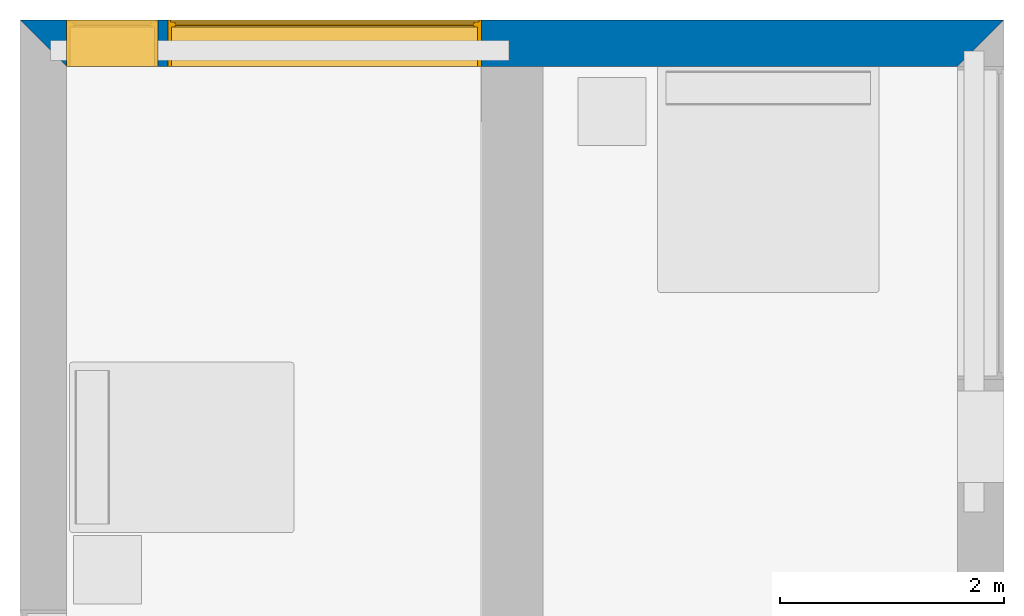
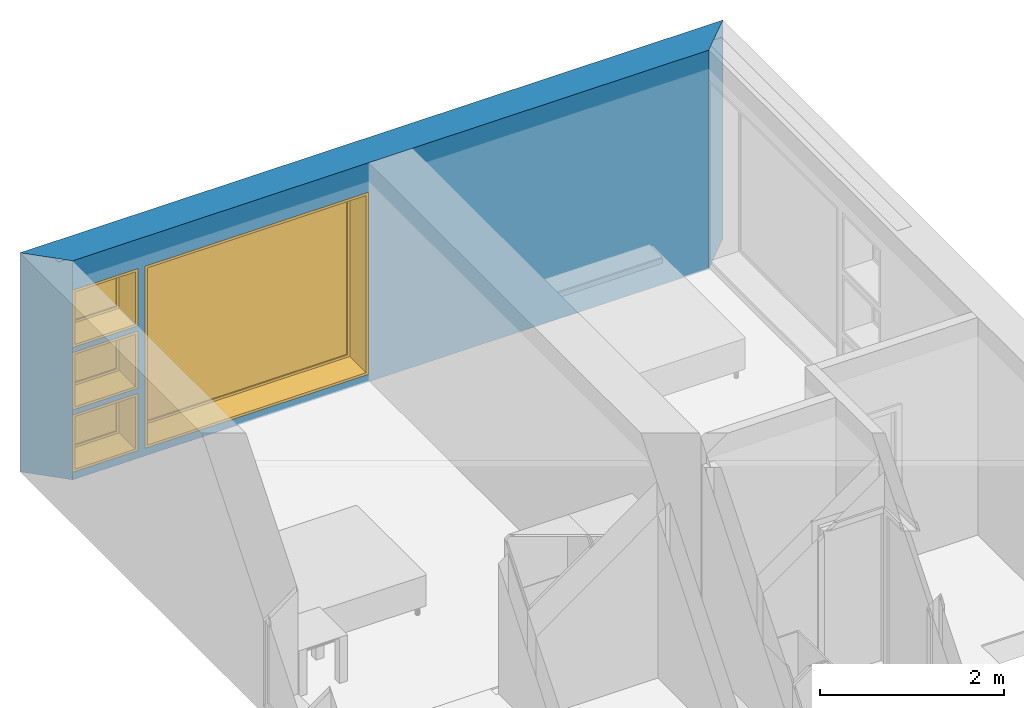
# One storey, part 4 of 16: 4 windows, 1 wall, 4 openings.
"""IFC2X3 building model written with IfcOpenShell, lengths in metres."""

from ifc_helpers import new_model, entity, si_unit, converted_unit, frame, frame_2d, origin, origin_2d_with_axis, place, context, project, spatial, polyline, rectangle, outline, extrude, source, transform, mapped, material, layer, layer_set, layer_usage, type_object, type_shapes, element, fill, save


model = new_model("IFC2X3")

# Units and contexts
model_context = context("Model", 3, precision=1e-09, world=origin())
plan_context = context("Plan", 3, precision=1e-09, world=origin())
ifc_project = project(units=[si_unit("LENGTHUNIT", "METRE"), si_unit("AREAUNIT", "SQUARE_METRE"), si_unit("VOLUMEUNIT", "CUBIC_METRE"), converted_unit("PLANEANGLEUNIT", "DEGREE", entity("IfcRatioMeasure", 0.01745329251994328), si_unit("PLANEANGLEUNIT", "RADIAN"), dimensions=[0, 0, 0, 0, 0, 0, 0]), si_unit("TIMEUNIT", "SECOND")], contexts=[model_context, plan_context])

# Site, building, storey
site_placement = place(None, origin())
site = spatial("IfcSite", under=ifc_project, at=site_placement, CompositionType="ELEMENT")
building_placement = place(site_placement, origin())
building = spatial("IfcBuilding", under=site, at=building_placement, CompositionType="ELEMENT")
storey_placement = place(building_placement, frame((0.0, 0.0, 3.100000000000196)))
storey = spatial("IfcBuildingStorey", under=building, at=storey_placement, Name="Level 2", CompositionType="ELEMENT", Elevation=3.100000000000196)

# Wall, openings, windows
ifc_material_1 = material(Name="Masonry - Brick")
ifc_layer_1 = layer(ifc_material_1, 0.092)
ifc_material_2 = material(Name="Misc. Air Layers - Air Space")
ifc_layer_2 = layer(ifc_material_2, 0.025)
ifc_material_3 = material(Name="Insulation / Thermal Barriers - Rigid insulation")
ifc_layer_3 = layer(ifc_material_3, 0.05)
ifc_material_4 = material(Name="Masonry - Concrete Block")
ifc_layer_4 = layer(ifc_material_4, 0.193)
ifc_material_5 = material(Name="Metal - Stud Layer")
ifc_layer_5 = layer(ifc_material_5, 0.041)
ifc_material_6 = material(Name="Plasterboard")
ifc_layer_6 = layer(ifc_material_6, 0.016)
ifc_layer_set = layer_set([ifc_layer_1, ifc_layer_2, ifc_layer_3, ifc_layer_4, ifc_layer_5, ifc_layer_6], Name="Basic Wall:Exterior - Brick on Block")
ifc_layer_usage = layer_usage(ifc_layer_set, "AXIS2", "NEGATIVE", 0.2085000000000001)
wall_placement = place(storey_placement, frame((0.0, -0.2085000000000001, 0.0)))
wall = element("IfcWallStandardCase", 1, at=wall_placement, inside=storey, material=ifc_layer_usage, Name="Basic Wall:Exterior - Brick on Block", ObjectType="Basic Wall:Exterior - Brick on Block", context=model_context, shape_type="SweptSolid", body=[
    extrude(outline(polyline([(8.383000000000001, -0.2085000000000001), (8.8, 0.2085000000000001), (0.0, 0.2085000000000001), (0.4170000000000014, -0.2085000000000001), (4.125000000000002, -0.2085000000000001), (4.675000000000002, -0.2085000000000001), (8.383000000000001, -0.2085000000000001)])), origin(), (0.0, 0.0, 1.0), 2.900000000000012),
])
opening_1_placement = place(wall_placement, frame((1.325, -0.2084999999999999, 0.1000000000000011)))
opening_1 = element("IfcOpeningElement", 2, at=opening_1_placement, cuts=wall, ObjectType="Opening", context=model_context, shape_type="SweptSolid", body=[
    extrude(rectangle(XDim=2.409999999999996, YDim=2.8, at=frame_2d((1.204999999999998, 1.4), x_axis=(1.0, 0.0))), frame((0.0, 0.0, 0.0), z_axis=(0.0, 1.0, 0.0), x_axis=(0.0, 0.0, 1.0)), (0.0, 0.0, 1.0), 0.4170000000000001),
])
opening_2_placement = place(wall_placement, frame((0.4170000000000003, -0.2085000000000001, 0.100000000000006)))
opening_2 = element("IfcOpeningElement", 3, at=opening_2_placement, cuts=wall, ObjectType="Opening", context=model_context, shape_type="SweptSolid", body=[
    extrude(rectangle(XDim=0.7589999999999981, YDim=0.8189999999999996, at=frame_2d((0.379499999999999, 0.4095), x_axis=(1.0, 0.0))), frame((0.0, 0.0, 0.0), z_axis=(0.0, 1.0, 0.0), x_axis=(0.0, 0.0, 1.0)), (0.0, 0.0, 1.0), 0.4170000000000001),
])
opening_3_placement = place(wall_placement, frame((0.417000000000015, -0.2085000000000014, 0.9254999999999997)))
opening_3 = element("IfcOpeningElement", 4, at=opening_3_placement, cuts=wall, ObjectType="Opening", context=model_context, shape_type="SweptSolid", body=[
    extrude(rectangle(XDim=0.7590000000000007, YDim=0.8189999999999998, at=frame_2d((0.3795000000000003, 0.4094999999999999), x_axis=(-1.0, 0.0))), frame((0.0, 0.0, 0.0), z_axis=(0.0, 1.0, 0.0), x_axis=(0.0, 0.0, 1.0)), (0.0, 0.0, 1.0), 0.4170000000000001),
])
opening_4_placement = place(wall_placement, frame((0.4170000000000002, -0.2085000000000001, 1.750999999999998)))
opening_4 = element("IfcOpeningElement", 5, at=opening_4_placement, cuts=wall, ObjectType="Opening", context=model_context, shape_type="SweptSolid", body=[
    extrude(rectangle(XDim=0.7589999999999981, YDim=0.8189999999999995, at=frame_2d((0.3794999999999993, 0.4094999999999998), x_axis=(1.0, 0.0))), frame((0.0, 0.0, 0.0), z_axis=(0.0, 1.0, 0.0), x_axis=(0.0, 0.0, 1.0)), (0.0, 0.0, 1.0), 0.4170000000000001),
])
window_style_1 = type_object("IfcWindowStyle", Name="2800mm x 2410mm", ConstructionType="NOTDEFINED", OperationType="NOTDEFINED", ParameterTakesPrecedence=False, Sizeable=False)
shared_shape_1 = source(origin(), model_context, "Body", "SweptSolid", [
    extrude(rectangle(XDim=0.01199999999999998, YDim=2.673999999999997, at=origin_2d_with_axis()), frame((1.400000000000007, 0.3759999999999956, 0.06299999999998514), z_axis=(0.0, 0.0, 1.0), x_axis=(0.0, -1.0, 0.0)), (0.0, 0.0, 1.0), 2.284000000000005),
    extrude(outline(polyline([(-1.381, -1.186000000000001), (1.381, -1.186000000000001), (1.381, 1.186000000000001), (-1.381, 1.186000000000001), (-1.381, -1.186000000000001)]), holes=[polyline([(-1.336999999999999, -1.142000000000002), (-1.336999999999999, 1.142000000000003), (1.336999999999997, 1.142000000000003), (1.336999999999997, -1.142000000000002), (-1.336999999999999, -1.142000000000002)])]), frame((1.400000000000008, 0.3539999999999681, 1.204999999999988), z_axis=(0.0, 1.0, 0.0), x_axis=(1.0, 0.0, 0.0)), (0.0, 0.0, 1.0), 0.04400000000002743),
    extrude(outline(polyline([(-1.4, -1.204999999999996), (1.4, -1.204999999999996), (1.4, 1.204999999999996), (-1.4, 1.204999999999996), (-1.4, -1.204999999999996)]), holes=[polyline([(-1.381000000000001, -1.185999999999981), (-1.381000000000001, 1.186000000000022), (1.380999999999999, 1.186000000000022), (1.380999999999999, -1.185999999999981), (-1.381000000000001, -1.185999999999981)])]), frame((1.400000000000009, 0.3539999999999681, 1.205000000000009), z_axis=(0.0, 1.0, 0.0), x_axis=(1.0, 0.0, 0.0)), (0.0, 0.0, 1.0), 0.06300000000002744),
    extrude(outline(polyline([(-1.4, -1.204999999999995), (1.4, -1.204999999999995), (1.4, 1.204999999999995), (-1.4, 1.204999999999995), (-1.4, -1.204999999999995)]), holes=[polyline([(-1.368, -1.172999999999982), (-1.368, 1.17300000000002), (1.368, 1.17300000000002), (1.367999999999999, -1.172999999999982), (-1.368, -1.172999999999982)])]), frame((1.40000000000001, 0.0, 1.205000000000008), z_axis=(0.0, 1.0, 0.0), x_axis=(1.0, 0.0, 0.0)), (0.0, 0.0, 1.0), 0.3539999999999727),
])
type_shapes(window_style_1, [shared_shape_1])
window_1_placement = place(opening_1_placement, origin())
window_1 = element("IfcWindow", 6, at=window_1_placement, inside=storey, type_object=window_style_1, ObjectType="2800mm x 2410mm", OverallHeight=2.409999999999996, OverallWidth=2.8, context=model_context, shape_type="MappedRepresentation", body=[
    mapped(shared_shape_1, transform((0.0, 0.0, 0.0), scale=1.0)),
])
fill(opening_1, window_1)
window_style_2 = type_object("IfcWindowStyle", Name="819mm x 759mm", ConstructionType="NOTDEFINED", OperationType="NOTDEFINED", ParameterTakesPrecedence=False, Sizeable=False)
shared_shape_2 = source(origin(), model_context, "Body", "SweptSolid", [
    extrude(rectangle(XDim=0.01199999999999998, YDim=0.6929999999999971, at=origin_2d_with_axis()), frame((0.4095000000000068, 0.3759999999999988, 0.06299999999998514), z_axis=(0.0, 0.0, 1.0), x_axis=(0.0, -1.0, 0.0)), (0.0, 0.0, 1.0), 0.6330000000000073),
    extrude(outline(polyline([(-0.3904999999999999, -0.3605000000000028), (0.3904999999999999, -0.3605000000000028), (0.3904999999999999, 0.3605000000000027), (-0.3904999999999999, 0.3605000000000027), (-0.3904999999999999, -0.3605000000000028)]), holes=[polyline([(-0.3464999999999996, -0.3165000000000033), (-0.3464999999999996, 0.316500000000004), (0.3464999999999974, 0.316500000000004), (0.3464999999999974, -0.3165000000000033), (-0.3464999999999996, -0.3165000000000033)])]), frame((0.4095000000000078, 0.3539999999999714, 0.3794999999999891), z_axis=(0.0, 1.0, 0.0), x_axis=(1.0, 0.0, 0.0)), (0.0, 0.0, 1.0), 0.04400000000002743),
    extrude(outline(polyline([(-0.4094999999999998, -0.3794999999999972), (0.4094999999999998, -0.3794999999999972), (0.4094999999999998, 0.3794999999999971), (-0.4094999999999998, 0.3794999999999971), (-0.4094999999999998, -0.3794999999999972)]), holes=[polyline([(-0.3905000000000011, -0.3604999999999823), (-0.3905000000000012, 0.3605000000000231), (0.3904999999999986, 0.3605000000000231), (0.3904999999999987, -0.3604999999999823), (-0.3905000000000011, -0.3604999999999823)])]), frame((0.4095000000000091, 0.3539999999999714, 0.3795000000000096), z_axis=(0.0, 1.0, 0.0), x_axis=(1.0, 0.0, 0.0)), (0.0, 0.0, 1.0), 0.06300000000002744),
    extrude(outline(polyline([(-0.4095000000000002, -0.3794999999999967), (0.4095000000000002, -0.3794999999999967), (0.4095000000000002, 0.3794999999999966), (-0.4095000000000002, 0.3794999999999966), (-0.4095000000000002, -0.3794999999999967)]), holes=[polyline([(-0.3774999999999999, -0.3474999999999832), (-0.3774999999999999, 0.3475000000000212), (0.3775000000000001, 0.3475000000000212), (0.3775000000000001, -0.3474999999999832), (-0.3774999999999999, -0.3474999999999832)])]), frame((0.4095000000000096, 0.0, 0.379500000000009), z_axis=(0.0, 1.0, 0.0), x_axis=(1.0, 0.0, 0.0)), (0.0, 0.0, 1.0), 0.3539999999999727),
])
type_shapes(window_style_2, [shared_shape_2])
window_2_placement = place(opening_2_placement, origin())
window_2 = element("IfcWindow", 7, at=window_2_placement, inside=storey, type_object=window_style_2, ObjectType="819mm x 759mm", OverallHeight=0.758999999999998, OverallWidth=0.8189999999999998, context=model_context, shape_type="MappedRepresentation", body=[
    mapped(shared_shape_2, transform((0.0, 0.0, 0.0), scale=1.0)),
])
fill(opening_2, window_2)
window_3_placement = place(opening_4_placement, origin())
window_3 = element("IfcWindow", 8, at=window_3_placement, inside=storey, type_object=window_style_2, ObjectType="819mm x 759mm", OverallHeight=0.7589999999999986, OverallWidth=0.8189999999999995, context=model_context, shape_type="MappedRepresentation", body=[
    mapped(shared_shape_2, transform((0.0, 0.0, 0.0), scale=1.0)),
])
fill(opening_4, window_3)
window_style_3 = type_object("IfcWindowStyle", Name="819mm x 759mm", ConstructionType="NOTDEFINED", OperationType="NOTDEFINED", ParameterTakesPrecedence=False, Sizeable=False)
shared_shape_3 = source(origin(), model_context, "Body", "SweptSolid", [
    extrude(rectangle(XDim=0.01269999999999999, YDim=0.6919999999999978, at=origin_2d_with_axis()), frame((0.4095000000000003, 0.3757750000000001, 0.06350000000000397), z_axis=(0.0, 0.0, 1.0), x_axis=(0.0, 1.0, 0.0)), (0.0, 0.0, 1.0), 0.6320000000000041),
    extrude(outline(polyline([(-0.3904499999999989, -0.3604500000000012), (0.3904499999999989, -0.3604500000000012), (0.3904499999999989, 0.3604500000000012), (-0.3904499999999989, 0.3604500000000012), (-0.3904499999999989, -0.3604500000000012)]), holes=[polyline([(-0.3459999999999978, -0.3160000000000016), (-0.3459999999999978, 0.3160000000000026), (0.346, 0.3160000000000026), (0.346, -0.3160000000000016), (-0.3459999999999978, -0.3160000000000016)])]), frame((0.4094999999999992, 0.3535500000000001, 0.3795000000000066), z_axis=(0.0, 1.0, 0.0), x_axis=(1.0, 0.0, 0.0)), (0.0, 0.0, 1.0), 0.04445),
    extrude(outline(polyline([(-0.4094999999999992, -0.3795000000000012), (0.4094999999999992, -0.3795000000000012), (0.4094999999999992, 0.3795000000000012), (-0.4094999999999992, 0.3795000000000012), (-0.4094999999999992, -0.3795000000000012)]), holes=[polyline([(-0.3777500000000001, -0.3477499999999997), (-0.3777500000000001, 0.3477500000000008), (0.3777499999999982, 0.3477500000000008), (0.3777499999999982, -0.3477499999999997), (-0.3777500000000001, -0.3477499999999997)])]), frame((0.4095000000000007, 0.0, 0.3795000000000077), z_axis=(0.0, 1.0, 0.0), x_axis=(1.0, 0.0, 0.0)), (0.0, 0.0, 1.0), 0.3535500000000001),
    extrude(outline(polyline([(-0.3795000000000017, -0.4094999999999995), (0.3795000000000017, -0.4094999999999995), (0.3795000000000017, 0.4094999999999995), (-0.3795000000000017, 0.4094999999999995), (-0.3795000000000017, -0.4094999999999995)]), holes=[polyline([(-0.3604500000000023, -0.3904499999999987), (-0.3604500000000023, 0.3904499999999997), (0.3604500000000017, 0.3904499999999997), (0.3604500000000017, -0.3904499999999988), (-0.3604500000000023, -0.3904499999999987)])]), frame((0.4095000000000004, 0.3535500000000001, 0.3795000000000071), z_axis=(0.0, 1.0, 0.0), x_axis=(0.0, 0.0, -1.0)), (0.0, 0.0, 1.0), 0.06345),
])
type_shapes(window_style_3, [shared_shape_3])
window_4_placement = place(opening_3_placement, origin())
window_4 = element("IfcWindow", 9, at=window_4_placement, inside=storey, type_object=window_style_3, ObjectType="819mm x 759mm", OverallHeight=0.7590000000000007, OverallWidth=0.819, context=model_context, shape_type="MappedRepresentation", body=[
    mapped(shared_shape_3, transform((0.0, 0.0, 0.0), scale=1.0)),
])
fill(opening_3, window_4)

save(model, "model.ifc")
